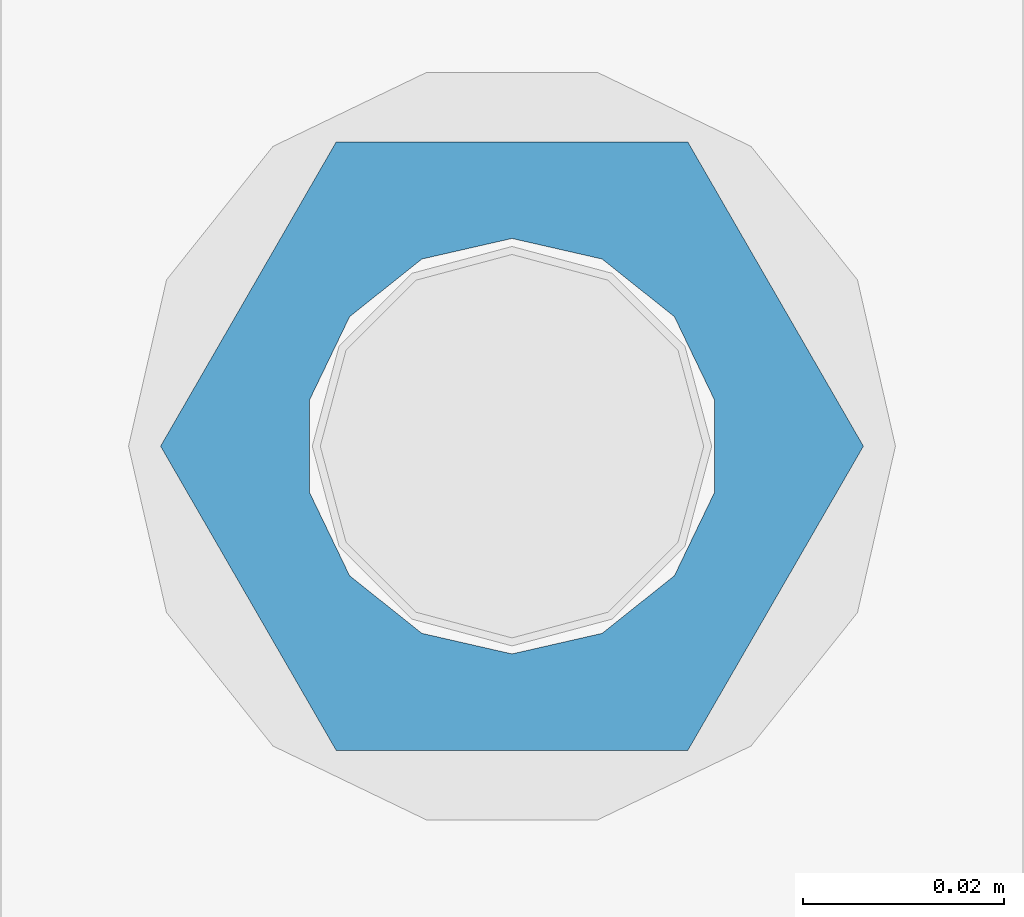
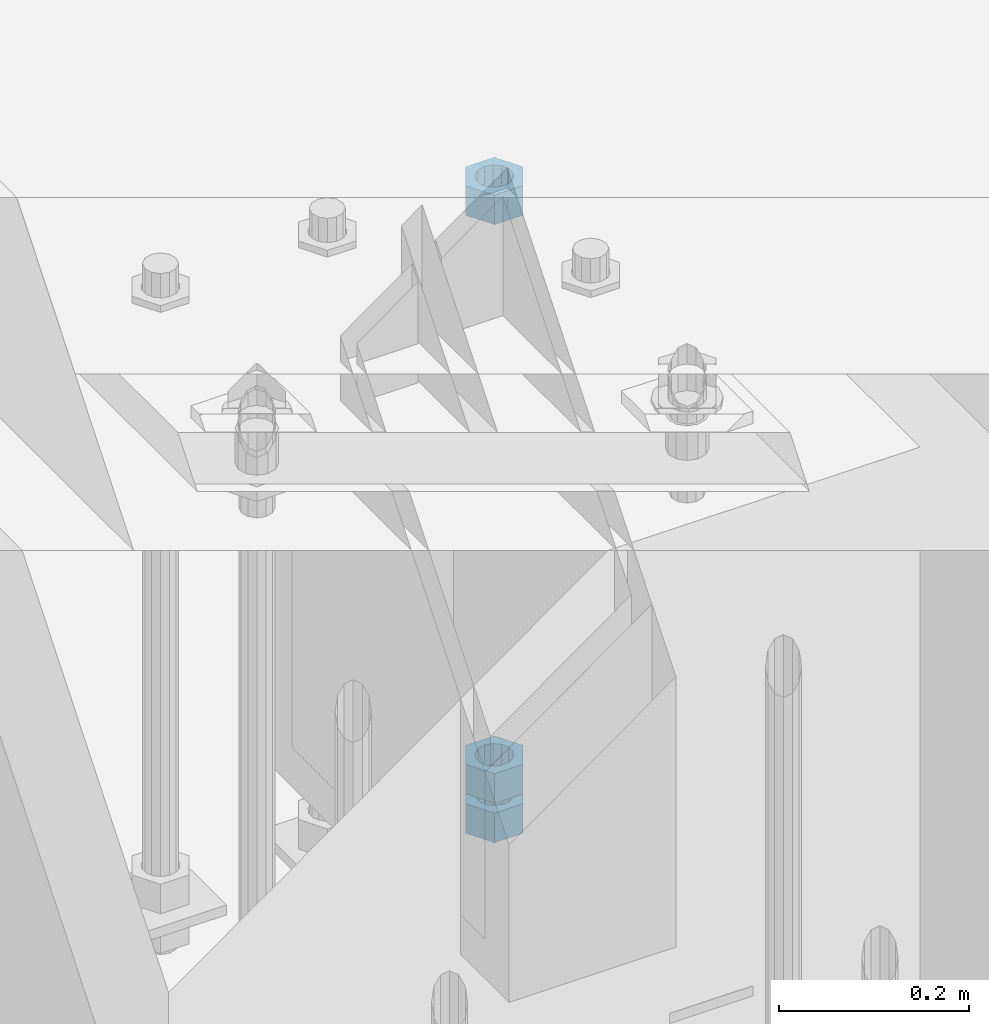
# One storey, part 990 of 1763: 3 columns, 1 element without a shape of its own.
"""IFC2X3 building model written with IfcOpenShell, lengths in millimetres."""

from ifc_helpers import new_model, si_unit, frame, origin_with_axes, place, context, subcontext, project, spatial, faceted_brep, material, type_object, element, aggregate, save


model = new_model("IFC2X3")

# Units and contexts
model_context = context("Model", 3, precision=1e-05, world=origin_with_axes())
body_context = subcontext(model_context, "Body", "Model", "MODEL_VIEW")
ifc_project = project(units=[si_unit("LENGTHUNIT", "METRE", prefix="MILLI"), si_unit("AREAUNIT", "SQUARE_METRE"), si_unit("VOLUMEUNIT", "CUBIC_METRE"), si_unit("MASSUNIT", "GRAM", prefix="KILO"), si_unit("TIMEUNIT", "SECOND"), si_unit("PLANEANGLEUNIT", "RADIAN"), si_unit("SOLIDANGLEUNIT", "STERADIAN"), si_unit("THERMODYNAMICTEMPERATUREUNIT", "DEGREE_CELSIUS"), si_unit("LUMINOUSINTENSITYUNIT", "LUMEN")], contexts=[model_context])

# Site, building, storey
site_placement = place(None, origin_with_axes())
site = spatial("IfcSite", under=ifc_project, at=site_placement, CompositionType="ELEMENT")
building_placement = place(site_placement, origin_with_axes())
building = spatial("IfcBuilding", under=site, at=building_placement, Name="Undefined", CompositionType="ELEMENT")
storey_placement = place(building_placement, origin_with_axes())
storey = spatial("IfcBuildingStorey", under=building, at=storey_placement, Name="Undefined", CompositionType="ELEMENT", Elevation=0.0)

# Assembly, columns
assembly_placement = place(storey_placement, origin_with_axes())
assembly = element("IfcElementAssembly", 1, at=assembly_placement, inside=storey, Name="TEMPLATE", AssemblyPlace="NOTDEFINED", PredefinedType="RIGID_FRAME")
ifc_material = material(Name="STEEL/A563")
column_type = type_object("IfcColumnType", Name="1-1/2_HEAVY_HEX_NUT", PredefinedType="NOTDEFINED")
column_1_placement = place(assembly_placement, frame((-87172.2372736984, 8839.20000000001, 5189.53750000001), z_axis=(0.0, 1.0, 0.0), x_axis=(0.0, 0.0, -1.0)))
column_1 = element("IfcColumn", 2, at=column_1_placement, type_object=column_type, material=ifc_material, Name="NUT", ObjectType="1-1/2_HEAVY_HEX_NUT", context=body_context, shape_type="Brep", body=[
    faceted_brep([(0.0, -34.9199981689453, 0.0), (0.0, -17.4599990844727, -30.25), (38.1000000000004, -17.4599990844727, -30.25), (38.1000000000004, -34.9199981689453, 0.0), (0.0, 17.4599990844727, -30.25), (38.1000000000004, 17.4599990844727, -30.25), (0.0, 34.9199981689453, 0.0), (38.1000000000004, 34.9199981689453, 0.0), (0.0, 17.4599990844727, 30.25), (38.1000000000004, 17.4599990844727, 30.25), (0.0, -17.4599990844727, 30.25), (38.1000000000004, -17.4599990844727, 30.25), (0.0, 0.0, 20.6399993896484), (0.0, 8.95536011056538, 18.5959968835978), (38.1000000000004, 8.95536011056538, 18.5959968835978), (38.1000000000004, 0.0, 20.6399993896484), (0.0, 16.1370013209453, 12.8688291298167), (38.1000000000004, 16.1370013209453, 12.8688291298167), (0.0, 20.1225115123816, 4.59283194104137), (38.1000000000004, 20.1225115123816, 4.59283194104137), (0.0, 20.1225115123816, -4.59283194104319), (38.1000000000004, 20.1225115123816, -4.59283194104319), (0.0, 16.1370013209453, -12.8688291298167), (38.1000000000004, 16.1370013209453, -12.8688291298167), (0.0, 8.95536011056538, -18.5959968835978), (38.1000000000004, 8.95536011056538, -18.5959968835978), (0.0, 0.0, -20.6399993896484), (38.1000000000004, 0.0, -20.6399993896484), (0.0, -8.95536011056538, -18.5959968835978), (38.1000000000004, -8.95536011056538, -18.5959968835978), (0.0, -16.1370013209453, -12.8688291298167), (38.1000000000004, -16.1370013209453, -12.8688291298167), (0.0, -20.1225115123816, -4.59283194104137), (38.1000000000004, -20.1225115123816, -4.59283194104137), (0.0, -20.1225115123816, 4.59283194104319), (38.1000000000004, -20.1225115123816, 4.59283194104319), (0.0, -16.1370013209453, 12.8688291298167), (38.1000000000004, -16.1370013209453, 12.8688291298167), (0.0, -8.95536011056538, 18.5959968835978), (38.1000000000004, -8.95536011056538, 18.5959968835978)], [[[0, 1, 2, 3]], [[1, 4, 5, 2]], [[4, 6, 7, 5]], [[6, 8, 9, 7]], [[8, 10, 11, 9]], [[10, 0, 3, 11]], [[12, 13, 14, 15]], [[13, 16, 17, 14]], [[16, 18, 19, 17]], [[18, 20, 21, 19]], [[20, 22, 23, 21]], [[22, 24, 25, 23]], [[24, 26, 27, 25]], [[26, 28, 29, 27]], [[28, 30, 31, 29]], [[30, 32, 33, 31]], [[32, 34, 35, 33]], [[34, 36, 37, 35]], [[36, 38, 39, 37]], [[38, 12, 15, 39]], [[5, 7, 9, 11, 3, 2], [17, 19, 21, 23, 25, 27, 29, 31, 33, 35, 37, 39, 15, 14]], [[10, 8, 6, 4, 1, 0], [38, 36, 34, 32, 30, 28, 26, 24, 22, 20, 18, 16, 13, 12]]]),
])
column_2_placement = place(assembly_placement, frame((-87172.2372736984, 8839.20000000001, 4445.00000000001), z_axis=(0.0, 1.0, 0.0), x_axis=(0.0, 0.0, -1.0)))
column_2 = element("IfcColumn", 3, at=column_2_placement, type_object=column_type, material=ifc_material, Name="NUT", ObjectType="1-1/2_HEAVY_HEX_NUT", context=body_context, shape_type="Brep", body=[
    faceted_brep([(0.0, -34.9199981689453, 0.0), (0.0, -17.4599990844727, -30.25), (38.1000000000004, -17.4599990844727, -30.25), (38.1000000000004, -34.9199981689453, 0.0), (0.0, 17.4599990844727, -30.25), (38.1000000000004, 17.4599990844727, -30.25), (0.0, 34.9199981689453, 0.0), (38.1000000000004, 34.9199981689453, 0.0), (0.0, 17.4599990844727, 30.25), (38.1000000000004, 17.4599990844727, 30.25), (0.0, -17.4599990844727, 30.25), (38.1000000000004, -17.4599990844727, 30.25), (0.0, 0.0, 20.6399993896484), (0.0, 8.95536011056538, 18.5959968835978), (38.1000000000004, 8.95536011056538, 18.5959968835978), (38.1000000000004, 0.0, 20.6399993896484), (0.0, 16.1370013209453, 12.8688291298167), (38.1000000000004, 16.1370013209453, 12.8688291298167), (0.0, 20.1225115123816, 4.59283194104137), (38.1000000000004, 20.1225115123816, 4.59283194104137), (0.0, 20.1225115123816, -4.59283194104319), (38.1000000000004, 20.1225115123816, -4.59283194104319), (0.0, 16.1370013209453, -12.8688291298167), (38.1000000000004, 16.1370013209453, -12.8688291298167), (0.0, 8.95536011056538, -18.5959968835978), (38.1000000000004, 8.95536011056538, -18.5959968835978), (0.0, 0.0, -20.6399993896484), (38.1000000000004, 0.0, -20.6399993896484), (0.0, -8.95536011056538, -18.5959968835978), (38.1000000000004, -8.95536011056538, -18.5959968835978), (0.0, -16.1370013209453, -12.8688291298167), (38.1000000000004, -16.1370013209453, -12.8688291298167), (0.0, -20.1225115123816, -4.59283194104137), (38.1000000000004, -20.1225115123816, -4.59283194104137), (0.0, -20.1225115123816, 4.59283194104319), (38.1000000000004, -20.1225115123816, 4.59283194104319), (0.0, -16.1370013209453, 12.8688291298167), (38.1000000000004, -16.1370013209453, 12.8688291298167), (0.0, -8.95536011056538, 18.5959968835978), (38.1000000000004, -8.95536011056538, 18.5959968835978)], [[[0, 1, 2, 3]], [[1, 4, 5, 2]], [[4, 6, 7, 5]], [[6, 8, 9, 7]], [[8, 10, 11, 9]], [[10, 0, 3, 11]], [[12, 13, 14, 15]], [[13, 16, 17, 14]], [[16, 18, 19, 17]], [[18, 20, 21, 19]], [[20, 22, 23, 21]], [[22, 24, 25, 23]], [[24, 26, 27, 25]], [[26, 28, 29, 27]], [[28, 30, 31, 29]], [[30, 32, 33, 31]], [[32, 34, 35, 33]], [[34, 36, 37, 35]], [[36, 38, 39, 37]], [[38, 12, 15, 39]], [[5, 7, 9, 11, 3, 2], [17, 19, 21, 23, 25, 27, 29, 31, 33, 35, 37, 39, 15, 14]], [[10, 8, 6, 4, 1, 0], [38, 36, 34, 32, 30, 28, 26, 24, 22, 20, 18, 16, 13, 12]]]),
])
column_3_placement = place(assembly_placement, frame((-87172.2372736984, 8839.20000000001, 4394.20000000001), z_axis=(0.0, 1.0, 0.0), x_axis=(0.0, 0.0, -1.0)))
column_3 = element("IfcColumn", 4, at=column_3_placement, type_object=column_type, material=ifc_material, Name="NUT", ObjectType="1-1/2_HEAVY_HEX_NUT", context=body_context, shape_type="Brep", body=[
    faceted_brep([(0.0, -34.9199981689453, 0.0), (0.0, -17.4599990844727, -30.25), (38.1000000000004, -17.4599990844727, -30.25), (38.1000000000004, -34.9199981689453, 0.0), (0.0, 17.4599990844727, -30.25), (38.1000000000004, 17.4599990844727, -30.25), (0.0, 34.9199981689453, 0.0), (38.1000000000004, 34.9199981689453, 0.0), (0.0, 17.4599990844727, 30.25), (38.1000000000004, 17.4599990844727, 30.25), (0.0, -17.4599990844727, 30.25), (38.1000000000004, -17.4599990844727, 30.25), (0.0, 0.0, 20.6399993896484), (0.0, 8.95536011056538, 18.5959968835978), (38.1000000000004, 8.95536011056538, 18.5959968835978), (38.1000000000004, 0.0, 20.6399993896484), (0.0, 16.1370013209453, 12.8688291298167), (38.1000000000004, 16.1370013209453, 12.8688291298167), (0.0, 20.1225115123816, 4.59283194104137), (38.1000000000004, 20.1225115123816, 4.59283194104137), (0.0, 20.1225115123816, -4.59283194104319), (38.1000000000004, 20.1225115123816, -4.59283194104319), (0.0, 16.1370013209453, -12.8688291298167), (38.1000000000004, 16.1370013209453, -12.8688291298167), (0.0, 8.95536011056538, -18.5959968835978), (38.1000000000004, 8.95536011056538, -18.5959968835978), (0.0, 0.0, -20.6399993896484), (38.1000000000004, 0.0, -20.6399993896484), (0.0, -8.95536011056538, -18.5959968835978), (38.1000000000004, -8.95536011056538, -18.5959968835978), (0.0, -16.1370013209453, -12.8688291298167), (38.1000000000004, -16.1370013209453, -12.8688291298167), (0.0, -20.1225115123816, -4.59283194104137), (38.1000000000004, -20.1225115123816, -4.59283194104137), (0.0, -20.1225115123816, 4.59283194104319), (38.1000000000004, -20.1225115123816, 4.59283194104319), (0.0, -16.1370013209453, 12.8688291298167), (38.1000000000004, -16.1370013209453, 12.8688291298167), (0.0, -8.95536011056538, 18.5959968835978), (38.1000000000004, -8.95536011056538, 18.5959968835978)], [[[0, 1, 2, 3]], [[1, 4, 5, 2]], [[4, 6, 7, 5]], [[6, 8, 9, 7]], [[8, 10, 11, 9]], [[10, 0, 3, 11]], [[12, 13, 14, 15]], [[13, 16, 17, 14]], [[16, 18, 19, 17]], [[18, 20, 21, 19]], [[20, 22, 23, 21]], [[22, 24, 25, 23]], [[24, 26, 27, 25]], [[26, 28, 29, 27]], [[28, 30, 31, 29]], [[30, 32, 33, 31]], [[32, 34, 35, 33]], [[34, 36, 37, 35]], [[36, 38, 39, 37]], [[38, 12, 15, 39]], [[5, 7, 9, 11, 3, 2], [17, 19, 21, 23, 25, 27, 29, 31, 33, 35, 37, 39, 15, 14]], [[10, 8, 6, 4, 1, 0], [38, 36, 34, 32, 30, 28, 26, 24, 22, 20, 18, 16, 13, 12]]]),
])
aggregate(assembly, [column_1, column_2, column_3])

save(model, "model.ifc")
